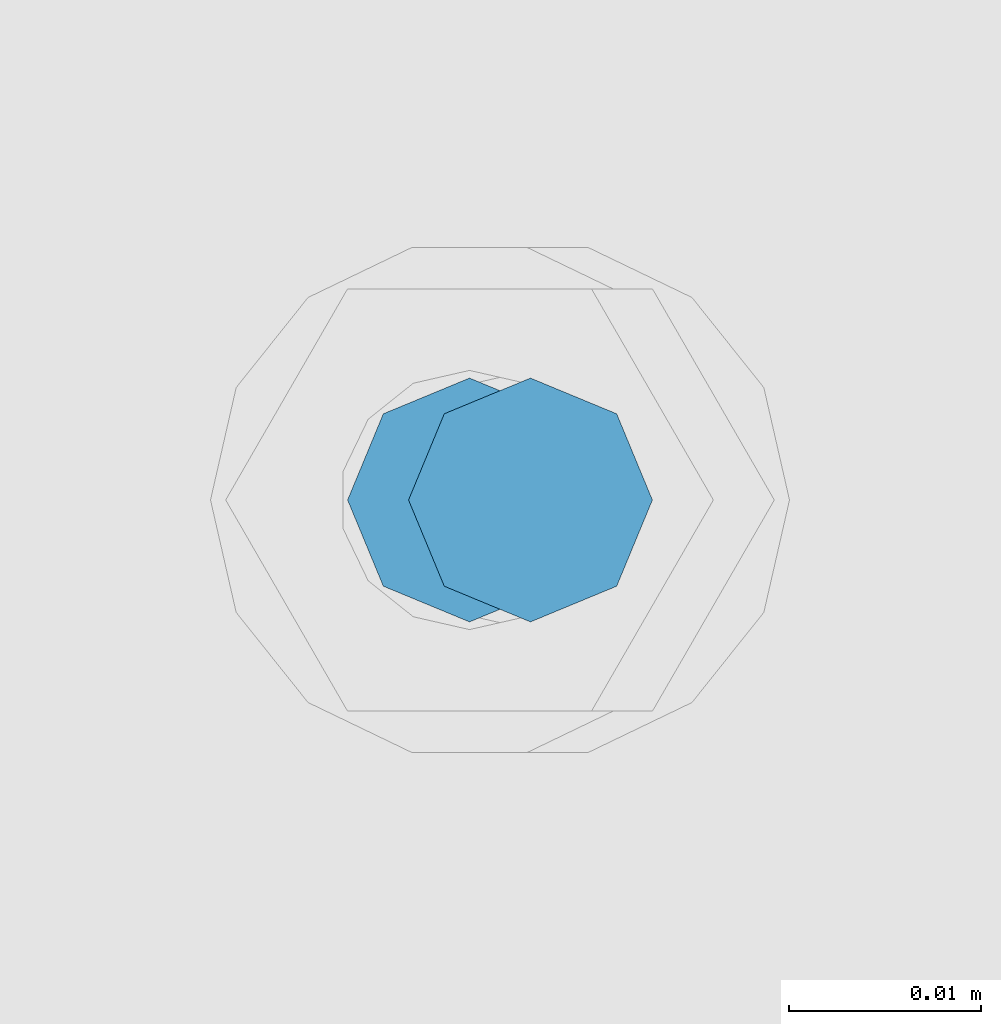
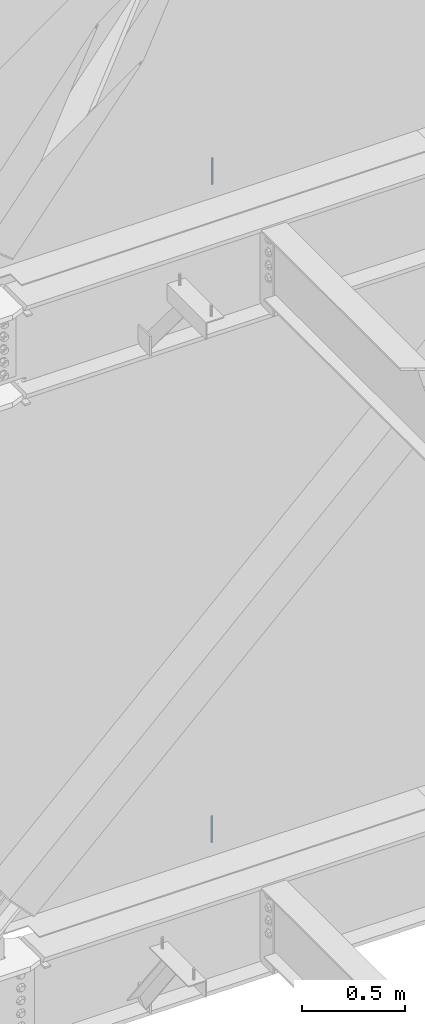
# One storey, part 535 of 1179: 2 columns, 2 elements without a shape of their own.
"""IFC2X3 building model written with IfcOpenShell, lengths in millimetres."""

import ifcopenshell
import ifcopenshell.guid

model = None  # the IFC model being written
_history = None  # IfcOwnerHistory: only IFC2X3 demands one
_inside = {}  # id of a spatial element -> (the spatial element, [elements in it])
_under = {}  # id of a project, library or spatial element -> (it, [spatial elements below it])
_declared = {}  # id of a project -> (the project, [libraries it declares])
_typed = {}  # id of a type object -> (the type object, [elements of that type])
_made_of = {}  # id of a material, layer set ... -> (it, [elements and type objects made of it])


def new_model(schema):
    """Start an empty IFC model of exactly this schema.

    Asked for "IFC4X3", IfcOpenShell would pick the latest addendum, in which some entities
    have other attributes; the version numbers below select the first issue.
    IFC2X3 requires an IfcOwnerHistory on every rooted entity: one is made here for all.
    """
    global model, _history
    if schema == "IFC4X3":
        model = ifcopenshell.file(schema_version=(4, 3, 0, 0))
    else:
        model = ifcopenshell.file(schema=schema)
    _inside.clear()
    _under.clear()
    _declared.clear()
    _typed.clear()
    _made_of.clear()
    _history = None
    if model.schema == "IFC2X3":
        org = make("IfcOrganization", Name="unknown")
        user = make(
            "IfcPersonAndOrganization",
            ThePerson=make("IfcPerson", FamilyName="unknown"),
            TheOrganization=org,
        )
        app = make(
            "IfcApplication",
            ApplicationDeveloper=org,
            Version="unknown",
            ApplicationFullName="unknown",
            ApplicationIdentifier="unknown",
        )
        _history = make(
            "IfcOwnerHistory",
            OwningUser=user,
            OwningApplication=app,
            ChangeAction="ADDED",
            CreationDate=0,
        )
    return model


def make(cls, **values):
    """One entity of the class cls with the attributes given. An attribute that is None is left unset."""
    return model.create_entity(
        cls, **{name: value for name, value in values.items() if value is not None}
    )


def rooted(cls, **values):
    """An entity with a GlobalId (a new one), such as an element, a storey or a relation."""
    return make(cls, GlobalId=ifcopenshell.guid.new(), OwnerHistory=_history, **values)


def si_unit(unit_type, name, prefix=None):
    """IfcSIUnit, for example si_unit("LENGTHUNIT", "METRE", prefix="MILLI")."""
    return make("IfcSIUnit", UnitType=unit_type, Prefix=prefix, Name=name)


def assignment(units):
    """IfcUnitAssignment: the units of a project."""
    return None if units is None else make("IfcUnitAssignment", Units=units)


def point(xyz):
    """IfcCartesianPoint."""
    return None if xyz is None else make("IfcCartesianPoint", Coordinates=xyz)


def direction(xyz):
    """IfcDirection."""
    return None if xyz is None else make("IfcDirection", DirectionRatios=xyz)


def frame(location, z_axis=None, x_axis=None):
    """IfcAxis2Placement3D, a coordinate frame: its origin and axes. An axis left out is left unset."""
    return make(
        "IfcAxis2Placement3D",
        Location=point(location),
        Axis=direction(z_axis),
        RefDirection=direction(x_axis),
    )


def origin_with_axes():
    """The frame at (0, 0, 0) with the z axis (0, 0, 1) and the x axis (1, 0, 0) written out."""
    return frame((0.0, 0.0, 0.0), z_axis=(0.0, 0.0, 1.0), x_axis=(1.0, 0.0, 0.0))


def place(relative_to, where):
    """IfcLocalPlacement: puts the frame where relative to a parent placement (None: the world)."""
    return make(
        "IfcLocalPlacement", PlacementRelTo=relative_to, RelativePlacement=where
    )


def context(
    kind, dimensions, precision=None, world=None, true_north=None, identifier=None
):
    """IfcGeometricRepresentationContext, for example the 3D "Model" context."""
    return make(
        "IfcGeometricRepresentationContext",
        ContextIdentifier=identifier,
        ContextType=kind,
        CoordinateSpaceDimension=dimensions,
        Precision=precision,
        WorldCoordinateSystem=world,
        TrueNorth=true_north,
    )


def subcontext(parent, identifier, kind, view, scale=None):
    """IfcGeometricRepresentationSubContext, for example "Body" below "Model"."""
    return make(
        "IfcGeometricRepresentationSubContext",
        ContextIdentifier=identifier,
        ContextType=kind,
        ParentContext=parent,
        TargetScale=scale,
        TargetView=view,
    )


def project(units=None, contexts=None):
    """IfcProject with its units and contexts."""
    return rooted(
        "IfcProject",
        Name="project",
        RepresentationContexts=contexts,
        UnitsInContext=assignment(units),
    )


def spatial(cls, under=None, at=None, **own):
    """A site, building, storey or space (cls), placed at a placement, below another one or the project."""
    s = rooted(cls, ObjectPlacement=at, **own)
    if under is not None:
        _under.setdefault(under.id(), (under, []))[1].append(s)
    return s


def faces_of(points, faces, orient=None, outer=None):
    """IfcFace entities. A face is a list of loops; a loop is a list of indices into points, from 0.

    orient and outer hold one flag for each loop. By default every Orientation is true, the
    first loop of a face is its IfcFaceOuterBound and the others are IfcFaceBound.
    """
    made = []
    for i, loops in enumerate(faces):
        bounds = []
        for j, loop in enumerate(loops):
            is_outer = j == 0 if outer is None else outer[i][j]
            bounds.append(
                make(
                    "IfcFaceOuterBound" if is_outer else "IfcFaceBound",
                    Bound=make("IfcPolyLoop", Polygon=[points[k] for k in loop]),
                    Orientation=True if orient is None else orient[i][j],
                )
            )
        made.append(make("IfcFace", Bounds=bounds))
    return made


def faceted_brep(points, faces, orient=None, outer=None, voids=None):
    """IfcFacetedBrep: a solid bounded by flat faces; with voids (closed shells), ...WithVoids."""
    shared = [point(p) for p in points]
    hull = make("IfcClosedShell", CfsFaces=faces_of(shared, faces, orient, outer))
    if voids is None:
        return make("IfcFacetedBrep", Outer=hull)
    return make(
        "IfcFacetedBrepWithVoids",
        Outer=hull,
        Voids=[
            make(cls, CfsFaces=faces_of(shared, fs, o, b)) for cls, fs, o, b in voids
        ],
    )


def shape(context_of_items, identifier, shape_type, items):
    """IfcShapeRepresentation: the items that make up one representation, for example the "Body"."""
    return make(
        "IfcShapeRepresentation",
        ContextOfItems=context_of_items,
        RepresentationIdentifier=identifier,
        RepresentationType=shape_type,
        Items=items,
    )


def material(Name=None, Category=None):
    """IfcMaterial."""
    return make("IfcMaterial", Name=Name, Category=Category)


def made_of(thing, what):
    """Note that an element or type object is made of a material, layer set ...; save() writes the relation."""
    if what is not None:
        _made_of.setdefault(what.id(), (what, []))[1].append(thing)
    return thing


def type_object(cls, material=None, **own):
    """A type object (cls), such as IfcWallType, which elements share."""
    return made_of(rooted(cls, **own), material)


def element(
    cls,
    number,
    at=None,
    inside=None,
    cuts=None,
    type_object=None,
    material=None,
    context=None,
    identifier="Body",
    shape_type=None,
    held_by="IfcProductDefinitionShape",
    body=None,
    shapes=None,
    **own,
):
    """One element of the class cls, such as IfcWall. Its Tag is "e" and its number.

    at: its placement. inside: the storey or other place that contains it. cuts: it is an
    opening in that element (IfcRelVoidsElement). A single representation is given by context,
    identifier, shape_type and body (its items); several are given by shapes. held_by: the class
    of the entity that holds the representations. save() writes the other relations.
    """
    e = rooted(cls, Tag="e%d" % number, ObjectPlacement=at, **own)
    if body is not None:
        shapes = [shape(context, identifier, shape_type, body)]
    if shapes is not None:
        e.Representation = make(held_by, Representations=shapes)
    if inside is not None:
        _inside.setdefault(inside.id(), (inside, []))[1].append(e)
    if cuts is not None:
        rooted(
            "IfcRelVoidsElement", RelatingBuildingElement=cuts, RelatedOpeningElement=e
        )
    if type_object is not None:
        _typed.setdefault(type_object.id(), (type_object, []))[1].append(e)
    return made_of(e, material)


def aggregate(whole, parts):
    """IfcRelAggregates: a whole, such as a stair, and the parts it consists of."""
    return rooted("IfcRelAggregates", RelatingObject=whole, RelatedObjects=parts)


def save(model, path):
    """Write the relations noted so far, then the file.

    IfcRelAggregates (storeys below a building ...), IfcRelContainedInSpatialStructure (elements
    in a storey), IfcRelDefinesByType, IfcRelAssociatesMaterial and IfcRelDeclares: one each for
    every whole, place, type object, material and project.
    """
    for whole, parts in _under.values():
        aggregate(whole, parts)
    for where, things in _inside.values():
        rooted(
            "IfcRelContainedInSpatialStructure",
            RelatedElements=things,
            RelatingStructure=where,
        )
    for kind, things in _typed.values():
        rooted("IfcRelDefinesByType", RelatedObjects=things, RelatingType=kind)
    for what, things in _made_of.values():
        rooted("IfcRelAssociatesMaterial", RelatedObjects=things, RelatingMaterial=what)
    for by, libraries in _declared.values():
        rooted("IfcRelDeclares", RelatingContext=by, RelatedDefinitions=libraries)
    model.write(path)


model = new_model("IFC2X3")

# Units and contexts
model_context = context("Model", 3, precision=1e-05, world=origin_with_axes())
body_context = subcontext(model_context, "Body", "Model", "MODEL_VIEW")
ifc_project = project(units=[si_unit("LENGTHUNIT", "METRE", prefix="MILLI"), si_unit("AREAUNIT", "SQUARE_METRE"), si_unit("VOLUMEUNIT", "CUBIC_METRE"), si_unit("MASSUNIT", "GRAM", prefix="KILO"), si_unit("TIMEUNIT", "SECOND"), si_unit("PLANEANGLEUNIT", "RADIAN"), si_unit("SOLIDANGLEUNIT", "STERADIAN"), si_unit("THERMODYNAMICTEMPERATUREUNIT", "DEGREE_CELSIUS"), si_unit("LUMINOUSINTENSITYUNIT", "LUMEN")], contexts=[model_context])

# Site, building, storey
site_placement = place(None, origin_with_axes())
site = spatial("IfcSite", under=ifc_project, at=site_placement, CompositionType="ELEMENT")
building_placement = place(site_placement, origin_with_axes())
building = spatial("IfcBuilding", under=site, at=building_placement, Name="Undefined", CompositionType="ELEMENT")
storey_placement = place(building_placement, origin_with_axes())
storey = spatial("IfcBuildingStorey", under=building, at=storey_placement, Name="Undefined", CompositionType="ELEMENT", Elevation=0.0)

# Assembly, column
assembly_1_placement = place(storey_placement, origin_with_axes())
assembly_1 = element("IfcElementAssembly", 1, at=assembly_1_placement, inside=storey, Name="BEAM", AssemblyPlace="NOTDEFINED", PredefinedType="RIGID_FRAME")
ifc_material = material(Name="STEEL/A307")
column_type = type_object("IfcColumnType", PredefinedType="NOTDEFINED")
column_1_placement = place(assembly_1_placement, frame((10239.375, 41529.0, 8020.05), z_axis=(0.0, 1.0, 0.0), x_axis=(0.0, 0.0, 1.0)))
column_1 = element("IfcColumn", 2, at=column_1_placement, type_object=column_type, material=ifc_material, Name="THREADED ROD", context=body_context, shape_type="Brep", body=[
    faceted_brep([(0.0, -6.34999999999854, 0.0), (0.0, -4.49012806053361, -4.49012806053452), (157.162499999999, -4.49012806053361, -4.49012806053361), (157.162499999999, -6.34999999999854, 0.0), (0.0, 0.0, -6.34999999999991), (157.162499999999, 0.0, -6.34999999999854), (0.0, 4.49012806053361, -4.49012806053452), (157.162499999999, 4.49012806053361, -4.49012806053361), (0.0, 6.34999999999854, 0.0), (157.162499999999, 6.34999999999854, 0.0), (0.0, 4.49012806053361, 4.49012806053452), (157.162499999999, 4.49012806053361, 4.49012806053361), (0.0, 0.0, 6.34999999999991), (157.162499999999, 0.0, 6.34999999999854), (0.0, -4.49012806053361, 4.49012806053452), (157.162499999999, -4.49012806053361, 4.49012806053361)], [[[0, 1, 2, 3]], [[1, 4, 5, 2]], [[4, 6, 7, 5]], [[6, 8, 9, 7]], [[8, 10, 11, 9]], [[10, 12, 13, 11]], [[12, 14, 15, 13]], [[14, 0, 3, 15]], [[5, 7, 9, 11, 13, 15, 3, 2]], [[14, 12, 10, 8, 6, 4, 1, 0]]]),
])
aggregate(assembly_1, [column_1])

assembly_2_placement = place(storey_placement, origin_with_axes())
assembly_2 = element("IfcElementAssembly", 3, at=assembly_2_placement, inside=storey, Name="BEAM", AssemblyPlace="NOTDEFINED", PredefinedType="RIGID_FRAME")
column_2_placement = place(assembly_2_placement, frame((10236.1999938965, 41529.0, 4108.45), z_axis=(0.0, 1.0, 0.0), x_axis=(0.0, 0.0, 1.0)))
column_2 = element("IfcColumn", 4, at=column_2_placement, type_object=column_type, material=ifc_material, Name="THREADED ROD", context=body_context, shape_type="Brep", body=[
    faceted_brep([(0.0, -6.34999999999854, 0.0), (0.0, -4.49012806053361, -4.49012806053452), (157.162499999999, -4.49012806053361, -4.49012806053361), (157.162499999999, -6.34999999999854, 0.0), (0.0, 0.0, -6.34999999999991), (157.162499999999, 0.0, -6.34999999999854), (0.0, 4.49012806053361, -4.49012806053452), (157.162499999999, 4.49012806053361, -4.49012806053361), (0.0, 6.34999999999854, 0.0), (157.162499999999, 6.34999999999854, 0.0), (0.0, 4.49012806053361, 4.49012806053452), (157.162499999999, 4.49012806053361, 4.49012806053361), (0.0, 0.0, 6.34999999999991), (157.162499999999, 0.0, 6.34999999999854), (0.0, -4.49012806053361, 4.49012806053452), (157.162499999999, -4.49012806053361, 4.49012806053361)], [[[0, 1, 2, 3]], [[1, 4, 5, 2]], [[4, 6, 7, 5]], [[6, 8, 9, 7]], [[8, 10, 11, 9]], [[10, 12, 13, 11]], [[12, 14, 15, 13]], [[14, 0, 3, 15]], [[5, 7, 9, 11, 13, 15, 3, 2]], [[14, 12, 10, 8, 6, 4, 1, 0]]]),
])
aggregate(assembly_2, [column_2])

save(model, "model.ifc")
